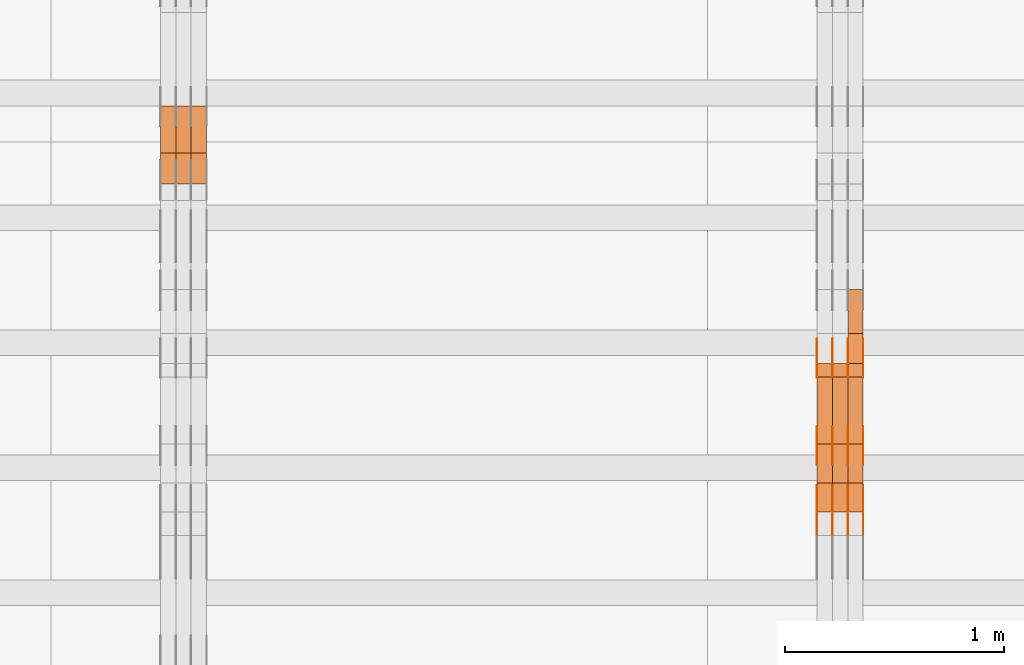
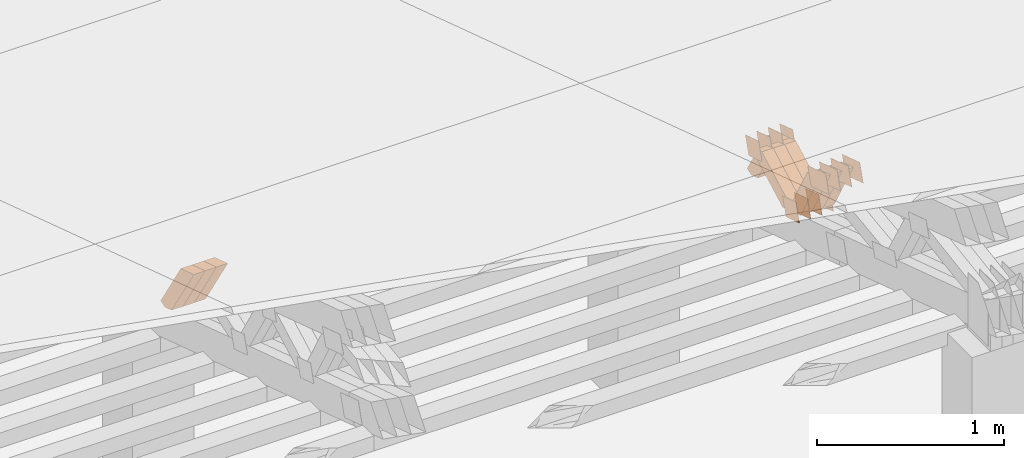
# One storey, part 225 of 385: 28 proxies.
"""IFC2X3 building model written with IfcOpenShell, lengths in millimetres."""

from ifc_helpers import new_model, entity, si_unit, converted_unit, derived_unit, direction, frame, origin, place, context, subcontext, project, spatial, polyline, outline, extrude, source, transform, mapped, material, type_object, type_shapes, element, save


model = new_model("IFC2X3")

# Units and contexts
model_context = context("Model", 3, precision=0.01, world=origin(), true_north=direction((6.12303176911189e-17, 1.0)))
body_context = subcontext(model_context, "Body", "Model", "MODEL_VIEW")
ifc_project = project(units=[si_unit("LENGTHUNIT", "METRE", prefix="MILLI"), si_unit("AREAUNIT", "SQUARE_METRE"), si_unit("VOLUMEUNIT", "CUBIC_METRE"), converted_unit("PLANEANGLEUNIT", "DEGREE", entity("IfcRatioMeasure", 0.0174532925199433), si_unit("PLANEANGLEUNIT", "RADIAN"), dimensions=[0, 0, 0, 0, 0, 0, 0]), si_unit("MASSUNIT", "GRAM", prefix="KILO"), derived_unit("MASSDENSITYUNIT", [(si_unit("MASSUNIT", "GRAM", prefix="KILO"), 1), (si_unit("LENGTHUNIT", "METRE"), -3)]), si_unit("TIMEUNIT", "SECOND"), si_unit("FREQUENCYUNIT", "HERTZ"), si_unit("THERMODYNAMICTEMPERATUREUNIT", "DEGREE_CELSIUS"), derived_unit("THERMALTRANSMITTANCEUNIT", [(si_unit("MASSUNIT", "GRAM", prefix="KILO"), 1), (si_unit("THERMODYNAMICTEMPERATUREUNIT", "KELVIN"), -1), (si_unit("TIMEUNIT", "SECOND"), -3)]), derived_unit("VOLUMETRICFLOWRATEUNIT", [(si_unit("LENGTHUNIT", "METRE"), 3), (si_unit("TIMEUNIT", "SECOND"), -1)]), si_unit("ELECTRICCURRENTUNIT", "AMPERE"), si_unit("ELECTRICVOLTAGEUNIT", "VOLT"), si_unit("POWERUNIT", "WATT"), si_unit("FORCEUNIT", "NEWTON", prefix="KILO"), si_unit("ILLUMINANCEUNIT", "LUX"), si_unit("LUMINOUSFLUXUNIT", "LUMEN"), si_unit("LUMINOUSINTENSITYUNIT", "CANDELA"), derived_unit("USERDEFINED", [(si_unit("MASSUNIT", "GRAM", prefix="KILO"), -1), (si_unit("LENGTHUNIT", "METRE"), -2), (si_unit("TIMEUNIT", "SECOND"), 3), (si_unit("LUMINOUSFLUXUNIT", "LUMEN"), 1)]), derived_unit("LINEARVELOCITYUNIT", [(si_unit("LENGTHUNIT", "METRE"), 1), (si_unit("TIMEUNIT", "SECOND"), -1)]), si_unit("PRESSUREUNIT", "PASCAL"), derived_unit("USERDEFINED", [(si_unit("LENGTHUNIT", "METRE"), -2), (si_unit("MASSUNIT", "GRAM", prefix="KILO"), 1), (si_unit("TIMEUNIT", "SECOND"), -2)])], contexts=[model_context])

# Site, building, storey
site_placement = place(None, origin())
site = spatial("IfcSite", under=ifc_project, at=site_placement, CompositionType="ELEMENT")
building_placement = place(site_placement, origin())
building = spatial("IfcBuilding", under=site, at=building_placement, CompositionType="ELEMENT")
storey_placement = place(building_placement, origin())
storey = spatial("IfcBuildingStorey", under=building, at=storey_placement, Name="Default", CompositionType="ELEMENT", Elevation=0.0)

# Proxies
ifc_material_1 = material(Name="IfcSurfaceStyle #348578")
building_element_proxy_type_1 = type_object("IfcBuildingElementProxyType", PredefinedType="NOTDEFINED", material=ifc_material_1)
shared_shape_1 = source(origin(), body_context, "Body", "SweptSolid", [
    extrude(outline(polyline([(-74.9998982809088, -60.000042563519), (74.9998377068237, -60.000042563519), (74.9998982809079, 60.0000425635189), (-74.9998377068227, 60.0000425635189), (-74.9998982809088, -60.000042563519)])), frame((75.0001050385304, 60.0001177331169, 0.0), z_axis=(0.0, 0.0, 1.0), x_axis=(-1.0, 0.0, 0.0)), (0.0, 0.0, 1.0), 1.3),
])
type_shapes(building_element_proxy_type_1, [shared_shape_1])
proxy_1_placement = place(building_placement, frame((27386.3, 19806.7306653882, 2506.65203571776), z_axis=(-1.0, 0.0, 0.0), x_axis=(0.0, -0.951056516295154, 0.309016994374948)))
element("IfcBuildingElementProxy", 1, at=proxy_1_placement, inside=storey, type_object=building_element_proxy_type_1, material=ifc_material_1, context=body_context, shape_type="MappedRepresentation", body=[
    mapped(shared_shape_1, transform((0.0, 0.0, 0.0), scale=1.0)),
])
ifc_material_2 = material(Name="IfcSurfaceStyle #348521")
building_element_proxy_type_2 = type_object("IfcBuildingElementProxyType", PredefinedType="NOTDEFINED", material=ifc_material_2)
shared_shape_2 = source(origin(), body_context, "Body", "SweptSolid", [
    extrude(outline(polyline([(-74.9998982809088, -60.000042563519), (74.9998377068237, -60.000042563519), (74.9998982809079, 60.0000425635189), (-74.9998377068227, 60.0000425635189), (-74.9998982809088, -60.000042563519)])), frame((75.0001050385304, 60.0001177331169, 0.0), z_axis=(0.0, 0.0, 1.0), x_axis=(-1.0, 0.0, 0.0)), (0.0, 0.0, 1.0), 1.3),
])
type_shapes(building_element_proxy_type_2, [shared_shape_2])
proxy_2_placement = place(building_placement, frame((27315.0, 19806.7306653882, 2506.65203571776), z_axis=(-1.0, 0.0, 0.0), x_axis=(0.0, -0.951056516295154, 0.309016994374948)))
element("IfcBuildingElementProxy", 2, at=proxy_2_placement, inside=storey, type_object=building_element_proxy_type_2, material=ifc_material_2, context=body_context, shape_type="MappedRepresentation", body=[
    mapped(shared_shape_2, transform((0.0, 0.0, 0.0), scale=1.0)),
])
ifc_material_3 = material(Name="IfcSurfaceStyle #348464")
building_element_proxy_type_3 = type_object("IfcBuildingElementProxyType", PredefinedType="NOTDEFINED", material=ifc_material_3)
shared_shape_3 = source(origin(), body_context, "Body", "SweptSolid", [
    extrude(outline(polyline([(-74.9998982809088, -60.000042563519), (74.9998377068237, -60.000042563519), (74.9998982809079, 60.0000425635189), (-74.9998377068227, 60.0000425635189), (-74.9998982809088, -60.000042563519)])), frame((75.0001050385304, 60.0001177331169, 0.0), z_axis=(0.0, 0.0, 1.0), x_axis=(-1.0, 0.0, 0.0)), (0.0, 0.0, 1.0), 1.3),
])
type_shapes(building_element_proxy_type_3, [shared_shape_3])
proxy_3_placement = place(building_placement, frame((27316.3, 19806.7306653882, 2506.65203571776), z_axis=(-1.0, 0.0, 0.0), x_axis=(0.0, -0.951056516295154, 0.309016994374948)))
element("IfcBuildingElementProxy", 3, at=proxy_3_placement, inside=storey, type_object=building_element_proxy_type_3, material=ifc_material_3, context=body_context, shape_type="MappedRepresentation", body=[
    mapped(shared_shape_3, transform((0.0, 0.0, 0.0), scale=1.0)),
])
ifc_material_4 = material(Name="IfcSurfaceStyle #348407")
building_element_proxy_type_4 = type_object("IfcBuildingElementProxyType", PredefinedType="NOTDEFINED", material=ifc_material_4)
shared_shape_4 = source(origin(), body_context, "Body", "SweptSolid", [
    extrude(outline(polyline([(-74.9998982809088, -60.000042563519), (74.9998377068237, -60.000042563519), (74.9998982809079, 60.0000425635189), (-74.9998377068227, 60.0000425635189), (-74.9998982809088, -60.000042563519)])), frame((75.0001050385304, 60.0001177331169, 0.0), z_axis=(0.0, 0.0, 1.0), x_axis=(-1.0, 0.0, 0.0)), (0.0, 0.0, 1.0), 1.29999999999999),
])
type_shapes(building_element_proxy_type_4, [shared_shape_4])
proxy_4_placement = place(building_placement, frame((27245.0, 19806.7306653882, 2506.65203571776), z_axis=(-1.0, 0.0, 0.0), x_axis=(0.0, -0.951056516295154, 0.309016994374948)))
element("IfcBuildingElementProxy", 4, at=proxy_4_placement, inside=storey, type_object=building_element_proxy_type_4, material=ifc_material_4, context=body_context, shape_type="MappedRepresentation", body=[
    mapped(shared_shape_4, transform((0.0, 0.0, 0.0), scale=1.0)),
])
ifc_material_5 = material(Name="IfcSurfaceStyle #348350")
building_element_proxy_type_5 = type_object("IfcBuildingElementProxyType", PredefinedType="NOTDEFINED", material=ifc_material_5)
shared_shape_5 = source(origin(), body_context, "Body", "SweptSolid", [
    extrude(outline(polyline([(-74.9998982809088, -60.000042563519), (74.9998377068237, -60.000042563519), (74.9998982809079, 60.0000425635189), (-74.9998377068227, 60.0000425635189), (-74.9998982809088, -60.000042563519)])), frame((75.0001050385304, 60.0001177331169, 0.0), z_axis=(0.0, 0.0, 1.0), x_axis=(-1.0, 0.0, 0.0)), (0.0, 0.0, 1.0), 1.29999999999999),
])
type_shapes(building_element_proxy_type_5, [shared_shape_5])
proxy_5_placement = place(building_placement, frame((27246.3, 19806.7306653882, 2506.65203571776), z_axis=(-1.0, 0.0, 0.0), x_axis=(0.0, -0.951056516295154, 0.309016994374948)))
element("IfcBuildingElementProxy", 5, at=proxy_5_placement, inside=storey, type_object=building_element_proxy_type_5, material=ifc_material_5, context=body_context, shape_type="MappedRepresentation", body=[
    mapped(shared_shape_5, transform((0.0, 0.0, 0.0), scale=1.0)),
])
ifc_material_6 = material(Name="IfcSurfaceStyle #348293")
building_element_proxy_type_6 = type_object("IfcBuildingElementProxyType", PredefinedType="NOTDEFINED", material=ifc_material_6)
shared_shape_6 = source(origin(), body_context, "Body", "SweptSolid", [
    extrude(outline(polyline([(-74.9998982809088, -60.000042563519), (74.9998377068237, -60.000042563519), (74.9998982809079, 60.0000425635189), (-74.9998377068227, 60.0000425635189), (-74.9998982809088, -60.000042563519)])), frame((75.0001050385304, 60.0001177331169, 0.0), z_axis=(0.0, 0.0, 1.0), x_axis=(-1.0, 0.0, 0.0)), (0.0, 0.0, 1.0), 1.29999999999999),
])
type_shapes(building_element_proxy_type_6, [shared_shape_6])
proxy_6_placement = place(building_placement, frame((27175.0, 19806.7306653882, 2506.65203571776), z_axis=(-1.0, 0.0, 0.0), x_axis=(0.0, -0.951056516295154, 0.309016994374948)))
element("IfcBuildingElementProxy", 6, at=proxy_6_placement, inside=storey, type_object=building_element_proxy_type_6, material=ifc_material_6, context=body_context, shape_type="MappedRepresentation", body=[
    mapped(shared_shape_6, transform((0.0, 0.0, 0.0), scale=1.0)),
])
ifc_material_7 = material(Name="IfcSurfaceStyle #347210")
building_element_proxy_type_7 = type_object("IfcBuildingElementProxyType", PredefinedType="NOTDEFINED", material=ifc_material_7)
shared_shape_7 = source(origin(), body_context, "Body", "SweptSolid", [
    extrude(outline(polyline([(-99.9998479918963, -59.9999913366637), (99.9998251396114, -59.9999913366637), (99.9998102700952, 59.9999913366637), (-99.9997874178102, 59.9999913366637), (-99.9998479918963, -59.9999913366637)])), frame((99.9998251396114, 60.0000609537942, 0.0), z_axis=(0.0, 0.0, 1.0), x_axis=(-1.0, 0.0, 0.0)), (0.0, 0.0, 1.0), 1.3),
])
type_shapes(building_element_proxy_type_7, [shared_shape_7])
proxy_7_placement = place(building_placement, frame((27386.3, 19136.9072023289, 2711.67346128215), z_axis=(-1.0, 0.0, 0.0), x_axis=(0.0, -0.951056516295154, 0.309016994374948)))
element("IfcBuildingElementProxy", 7, at=proxy_7_placement, inside=storey, type_object=building_element_proxy_type_7, material=ifc_material_7, context=body_context, shape_type="MappedRepresentation", body=[
    mapped(shared_shape_7, transform((0.0, 0.0, 0.0), scale=1.0)),
])
ifc_material_8 = material(Name="IfcSurfaceStyle #347153")
building_element_proxy_type_8 = type_object("IfcBuildingElementProxyType", PredefinedType="NOTDEFINED", material=ifc_material_8)
shared_shape_8 = source(origin(), body_context, "Body", "SweptSolid", [
    extrude(outline(polyline([(-99.9998479918963, -59.9999913366637), (99.9998251396114, -59.9999913366637), (99.9998102700952, 59.9999913366637), (-99.9997874178102, 59.9999913366637), (-99.9998479918963, -59.9999913366637)])), frame((99.9998251396114, 60.0000609537942, 0.0), z_axis=(0.0, 0.0, 1.0), x_axis=(-1.0, 0.0, 0.0)), (0.0, 0.0, 1.0), 1.3),
])
type_shapes(building_element_proxy_type_8, [shared_shape_8])
proxy_8_placement = place(building_placement, frame((27315.0, 19136.9072023289, 2711.67346128215), z_axis=(-1.0, 0.0, 0.0), x_axis=(0.0, -0.951056516295154, 0.309016994374948)))
element("IfcBuildingElementProxy", 8, at=proxy_8_placement, inside=storey, type_object=building_element_proxy_type_8, material=ifc_material_8, context=body_context, shape_type="MappedRepresentation", body=[
    mapped(shared_shape_8, transform((0.0, 0.0, 0.0), scale=1.0)),
])
ifc_material_9 = material(Name="IfcSurfaceStyle #347096")
building_element_proxy_type_9 = type_object("IfcBuildingElementProxyType", PredefinedType="NOTDEFINED", material=ifc_material_9)
shared_shape_9 = source(origin(), body_context, "Body", "SweptSolid", [
    extrude(outline(polyline([(-99.9998479918963, -59.9999913366637), (99.9998251396114, -59.9999913366637), (99.9998102700952, 59.9999913366637), (-99.9997874178102, 59.9999913366637), (-99.9998479918963, -59.9999913366637)])), frame((99.9998251396114, 60.0000609537942, 0.0), z_axis=(0.0, 0.0, 1.0), x_axis=(-1.0, 0.0, 0.0)), (0.0, 0.0, 1.0), 1.3),
])
type_shapes(building_element_proxy_type_9, [shared_shape_9])
proxy_9_placement = place(building_placement, frame((27316.3, 19136.9072023289, 2711.67346128215), z_axis=(-1.0, 0.0, 0.0), x_axis=(0.0, -0.951056516295154, 0.309016994374948)))
element("IfcBuildingElementProxy", 9, at=proxy_9_placement, inside=storey, type_object=building_element_proxy_type_9, material=ifc_material_9, context=body_context, shape_type="MappedRepresentation", body=[
    mapped(shared_shape_9, transform((0.0, 0.0, 0.0), scale=1.0)),
])
ifc_material_10 = material(Name="IfcSurfaceStyle #347039")
building_element_proxy_type_10 = type_object("IfcBuildingElementProxyType", PredefinedType="NOTDEFINED", material=ifc_material_10)
shared_shape_10 = source(origin(), body_context, "Body", "SweptSolid", [
    extrude(outline(polyline([(-99.9998479918963, -59.9999913366637), (99.9998251396114, -59.9999913366637), (99.9998102700952, 59.9999913366637), (-99.9997874178102, 59.9999913366637), (-99.9998479918963, -59.9999913366637)])), frame((99.9998251396114, 60.0000609537942, 0.0), z_axis=(0.0, 0.0, 1.0), x_axis=(-1.0, 0.0, 0.0)), (0.0, 0.0, 1.0), 1.29999999999998),
])
type_shapes(building_element_proxy_type_10, [shared_shape_10])
proxy_10_placement = place(building_placement, frame((27245.0, 19136.9072023289, 2711.67346128215), z_axis=(-1.0, 0.0, 0.0), x_axis=(0.0, -0.951056516295154, 0.309016994374948)))
element("IfcBuildingElementProxy", 10, at=proxy_10_placement, inside=storey, type_object=building_element_proxy_type_10, material=ifc_material_10, context=body_context, shape_type="MappedRepresentation", body=[
    mapped(shared_shape_10, transform((0.0, 0.0, 0.0), scale=1.0)),
])
ifc_material_11 = material(Name="IfcSurfaceStyle #346982")
building_element_proxy_type_11 = type_object("IfcBuildingElementProxyType", PredefinedType="NOTDEFINED", material=ifc_material_11)
shared_shape_11 = source(origin(), body_context, "Body", "SweptSolid", [
    extrude(outline(polyline([(-99.9998479918963, -59.9999913366637), (99.9998251396114, -59.9999913366637), (99.9998102700952, 59.9999913366637), (-99.9997874178102, 59.9999913366637), (-99.9998479918963, -59.9999913366637)])), frame((99.9998251396114, 60.0000609537942, 0.0), z_axis=(0.0, 0.0, 1.0), x_axis=(-1.0, 0.0, 0.0)), (0.0, 0.0, 1.0), 1.29999999999998),
])
type_shapes(building_element_proxy_type_11, [shared_shape_11])
proxy_11_placement = place(building_placement, frame((27246.3, 19136.9072023289, 2711.67346128215), z_axis=(-1.0, 0.0, 0.0), x_axis=(0.0, -0.951056516295154, 0.309016994374948)))
element("IfcBuildingElementProxy", 11, at=proxy_11_placement, inside=storey, type_object=building_element_proxy_type_11, material=ifc_material_11, context=body_context, shape_type="MappedRepresentation", body=[
    mapped(shared_shape_11, transform((0.0, 0.0, 0.0), scale=1.0)),
])
ifc_material_12 = material(Name="IfcSurfaceStyle #346925")
building_element_proxy_type_12 = type_object("IfcBuildingElementProxyType", PredefinedType="NOTDEFINED", material=ifc_material_12)
shared_shape_12 = source(origin(), body_context, "Body", "SweptSolid", [
    extrude(outline(polyline([(-99.9998479918963, -59.9999913366637), (99.9998251396114, -59.9999913366637), (99.9998102700952, 59.9999913366637), (-99.9997874178102, 59.9999913366637), (-99.9998479918963, -59.9999913366637)])), frame((99.9998251396114, 60.0000609537942, 0.0), z_axis=(0.0, 0.0, 1.0), x_axis=(-1.0, 0.0, 0.0)), (0.0, 0.0, 1.0), 1.29999999999999),
])
type_shapes(building_element_proxy_type_12, [shared_shape_12])
proxy_12_placement = place(building_placement, frame((27175.0, 19136.9072023289, 2711.67346128215), z_axis=(-1.0, 0.0, 0.0), x_axis=(0.0, -0.951056516295154, 0.309016994374948)))
element("IfcBuildingElementProxy", 12, at=proxy_12_placement, inside=storey, type_object=building_element_proxy_type_12, material=ifc_material_12, context=body_context, shape_type="MappedRepresentation", body=[
    mapped(shared_shape_12, transform((0.0, 0.0, 0.0), scale=1.0)),
])
ifc_material_13 = material(Name="IfcSurfaceStyle #342080")
building_element_proxy_type_13 = type_object("IfcBuildingElementProxyType", PredefinedType="NOTDEFINED", material=ifc_material_13)
shared_shape_13 = source(origin(), body_context, "Body", "SweptSolid", [
    extrude(outline(polyline([(-74.9998605591127, -59.9999264677599), (74.999875428618, -59.9999264677599), (74.9998605591127, 59.9999264677599), (-74.999875428618, 59.9999264677599), (-74.9998605591127, -59.9999264677599)])), frame((75.0002655673825, 60.0000016373433, 0.0), z_axis=(0.0, 0.0, 1.0), x_axis=(-1.0, 0.0, 0.0)), (0.0, 0.0, 1.0), 1.3),
])
type_shapes(building_element_proxy_type_13, [shared_shape_13])
proxy_13_placement = place(building_placement, frame((27386.3, 19407.1136664358, 2348.71056820494), z_axis=(-1.0, 0.0, 0.0), x_axis=(0.0, -0.951056516295124, 0.309016994375039)))
element("IfcBuildingElementProxy", 13, at=proxy_13_placement, inside=storey, type_object=building_element_proxy_type_13, material=ifc_material_13, context=body_context, shape_type="MappedRepresentation", body=[
    mapped(shared_shape_13, transform((0.0, 0.0, 0.0), scale=1.0)),
])
ifc_material_14 = material(Name="IfcSurfaceStyle #342023")
building_element_proxy_type_14 = type_object("IfcBuildingElementProxyType", PredefinedType="NOTDEFINED", material=ifc_material_14)
shared_shape_14 = source(origin(), body_context, "Body", "SweptSolid", [
    extrude(outline(polyline([(-74.9998605591127, -59.9999264677599), (74.999875428618, -59.9999264677599), (74.9998605591127, 59.9999264677599), (-74.999875428618, 59.9999264677599), (-74.9998605591127, -59.9999264677599)])), frame((75.0002655673825, 60.0000016373433, 0.0), z_axis=(0.0, 0.0, 1.0), x_axis=(-1.0, 0.0, 0.0)), (0.0, 0.0, 1.0), 1.3),
])
type_shapes(building_element_proxy_type_14, [shared_shape_14])
proxy_14_placement = place(building_placement, frame((27315.0, 19407.1136664358, 2348.71056820494), z_axis=(-1.0, 0.0, 0.0), x_axis=(0.0, -0.951056516295124, 0.309016994375039)))
element("IfcBuildingElementProxy", 14, at=proxy_14_placement, inside=storey, type_object=building_element_proxy_type_14, material=ifc_material_14, context=body_context, shape_type="MappedRepresentation", body=[
    mapped(shared_shape_14, transform((0.0, 0.0, 0.0), scale=1.0)),
])
ifc_material_15 = material(Name="IfcSurfaceStyle #341966")
building_element_proxy_type_15 = type_object("IfcBuildingElementProxyType", PredefinedType="NOTDEFINED", material=ifc_material_15)
shared_shape_15 = source(origin(), body_context, "Body", "SweptSolid", [
    extrude(outline(polyline([(-74.9998605591127, -59.9999264677599), (74.999875428618, -59.9999264677599), (74.9998605591127, 59.9999264677599), (-74.999875428618, 59.9999264677599), (-74.9998605591127, -59.9999264677599)])), frame((75.0002655673825, 60.0000016373433, 0.0), z_axis=(0.0, 0.0, 1.0), x_axis=(-1.0, 0.0, 0.0)), (0.0, 0.0, 1.0), 1.3),
])
type_shapes(building_element_proxy_type_15, [shared_shape_15])
proxy_15_placement = place(building_placement, frame((27316.3, 19407.1136664358, 2348.71056820494), z_axis=(-1.0, 0.0, 0.0), x_axis=(0.0, -0.951056516295124, 0.309016994375039)))
element("IfcBuildingElementProxy", 15, at=proxy_15_placement, inside=storey, type_object=building_element_proxy_type_15, material=ifc_material_15, context=body_context, shape_type="MappedRepresentation", body=[
    mapped(shared_shape_15, transform((0.0, 0.0, 0.0), scale=1.0)),
])
ifc_material_16 = material(Name="IfcSurfaceStyle #341909")
building_element_proxy_type_16 = type_object("IfcBuildingElementProxyType", PredefinedType="NOTDEFINED", material=ifc_material_16)
shared_shape_16 = source(origin(), body_context, "Body", "SweptSolid", [
    extrude(outline(polyline([(-74.9998605591127, -59.9999264677599), (74.999875428618, -59.9999264677599), (74.9998605591127, 59.9999264677599), (-74.999875428618, 59.9999264677599), (-74.9998605591127, -59.9999264677599)])), frame((75.0002655673825, 60.0000016373433, 0.0), z_axis=(0.0, 0.0, 1.0), x_axis=(-1.0, 0.0, 0.0)), (0.0, 0.0, 1.0), 1.29999999999999),
])
type_shapes(building_element_proxy_type_16, [shared_shape_16])
proxy_16_placement = place(building_placement, frame((27245.0, 19407.1136664358, 2348.71056820494), z_axis=(-1.0, 0.0, 0.0), x_axis=(0.0, -0.951056516295124, 0.309016994375039)))
element("IfcBuildingElementProxy", 16, at=proxy_16_placement, inside=storey, type_object=building_element_proxy_type_16, material=ifc_material_16, context=body_context, shape_type="MappedRepresentation", body=[
    mapped(shared_shape_16, transform((0.0, 0.0, 0.0), scale=1.0)),
])
ifc_material_17 = material(Name="IfcSurfaceStyle #341852")
building_element_proxy_type_17 = type_object("IfcBuildingElementProxyType", PredefinedType="NOTDEFINED", material=ifc_material_17)
shared_shape_17 = source(origin(), body_context, "Body", "SweptSolid", [
    extrude(outline(polyline([(-74.9998605591127, -59.9999264677599), (74.999875428618, -59.9999264677599), (74.9998605591127, 59.9999264677599), (-74.999875428618, 59.9999264677599), (-74.9998605591127, -59.9999264677599)])), frame((75.0002655673825, 60.0000016373433, 0.0), z_axis=(0.0, 0.0, 1.0), x_axis=(-1.0, 0.0, 0.0)), (0.0, 0.0, 1.0), 1.29999999999999),
])
type_shapes(building_element_proxy_type_17, [shared_shape_17])
proxy_17_placement = place(building_placement, frame((27246.3, 19407.1136664358, 2348.71056820494), z_axis=(-1.0, 0.0, 0.0), x_axis=(0.0, -0.951056516295124, 0.309016994375039)))
element("IfcBuildingElementProxy", 17, at=proxy_17_placement, inside=storey, type_object=building_element_proxy_type_17, material=ifc_material_17, context=body_context, shape_type="MappedRepresentation", body=[
    mapped(shared_shape_17, transform((0.0, 0.0, 0.0), scale=1.0)),
])
ifc_material_18 = material(Name="IfcSurfaceStyle #341795")
building_element_proxy_type_18 = type_object("IfcBuildingElementProxyType", PredefinedType="NOTDEFINED", material=ifc_material_18)
shared_shape_18 = source(origin(), body_context, "Body", "SweptSolid", [
    extrude(outline(polyline([(-74.9998605591127, -59.9999264677599), (74.999875428618, -59.9999264677599), (74.9998605591127, 59.9999264677599), (-74.999875428618, 59.9999264677599), (-74.9998605591127, -59.9999264677599)])), frame((75.0002655673825, 60.0000016373433, 0.0), z_axis=(0.0, 0.0, 1.0), x_axis=(-1.0, 0.0, 0.0)), (0.0, 0.0, 1.0), 1.29999999999999),
])
type_shapes(building_element_proxy_type_18, [shared_shape_18])
proxy_18_placement = place(building_placement, frame((27175.0, 19407.1136664358, 2348.71056820494), z_axis=(-1.0, 0.0, 0.0), x_axis=(0.0, -0.951056516295124, 0.309016994375039)))
element("IfcBuildingElementProxy", 18, at=proxy_18_placement, inside=storey, type_object=building_element_proxy_type_18, material=ifc_material_18, context=body_context, shape_type="MappedRepresentation", body=[
    mapped(shared_shape_18, transform((0.0, 0.0, 0.0), scale=1.0)),
])
ifc_material_19 = material(Name="IfcSurfaceStyle #325322")
building_element_proxy_type_19 = type_object("IfcBuildingElementProxyType", Name="T1-W40 325320", PredefinedType="NOTDEFINED", material=ifc_material_19)
shared_shape_19 = source(origin(), body_context, "Body", "SweptSolid", [
    extrude(outline(polyline([(-190.697067347251, -47.4992767218045), (178.704677543904, -47.4992767218045), (178.119540532346, -0.000296092407564622), (126.935785980356, 47.4999913795318), (-293.062936709355, 47.4988581564849), (-190.697067347251, -47.4992767218045)])), frame((178.7049897723, 47.4999913795318, 0.0), z_axis=(0.0, 0.0, 1.0), x_axis=(-1.0, 0.0, 0.0)), (0.0, 0.0, 1.0), 70.0),
])
type_shapes(building_element_proxy_type_19, [shared_shape_19])
proxy_19_placement = place(building_placement, frame((27385.0, 19280.269490882, 2403.36730959494), z_axis=(-1.0, 0.0, 0.0), x_axis=(0.0, -0.48691092455798, 0.873451630913866)))
element("IfcBuildingElementProxy", 19, at=proxy_19_placement, inside=storey, type_object=building_element_proxy_type_19, material=ifc_material_19, Name="T1-W40", context=body_context, shape_type="MappedRepresentation", body=[
    mapped(shared_shape_19, transform((0.0, 0.0, 0.0), scale=1.0)),
])
ifc_material_20 = material(Name="IfcSurfaceStyle #325256")
building_element_proxy_type_20 = type_object("IfcBuildingElementProxyType", Name="T1-W40 325254", PredefinedType="NOTDEFINED", material=ifc_material_20)
shared_shape_20 = source(origin(), body_context, "Body", "SweptSolid", [
    extrude(outline(polyline([(-190.697067347251, -47.4992767218045), (178.704677543904, -47.4992767218045), (178.119540532346, -0.000296092407564622), (126.935785980356, 47.4999913795318), (-293.062936709355, 47.4988581564849), (-190.697067347251, -47.4992767218045)])), frame((178.7049897723, 47.4999913795318, 0.0), z_axis=(0.0, 0.0, 1.0), x_axis=(-1.0, 0.0, 0.0)), (0.0, 0.0, 1.0), 70.0),
])
type_shapes(building_element_proxy_type_20, [shared_shape_20])
proxy_20_placement = place(building_placement, frame((27315.0, 19280.269490882, 2403.36730959494), z_axis=(-1.0, 0.0, 0.0), x_axis=(0.0, -0.48691092455798, 0.873451630913866)))
element("IfcBuildingElementProxy", 20, at=proxy_20_placement, inside=storey, type_object=building_element_proxy_type_20, material=ifc_material_20, Name="T1-W40", context=body_context, shape_type="MappedRepresentation", body=[
    mapped(shared_shape_20, transform((0.0, 0.0, 0.0), scale=1.0)),
])
ifc_material_21 = material(Name="IfcSurfaceStyle #325190")
building_element_proxy_type_21 = type_object("IfcBuildingElementProxyType", Name="T1-W40 325188", PredefinedType="NOTDEFINED", material=ifc_material_21)
shared_shape_21 = source(origin(), body_context, "Body", "SweptSolid", [
    extrude(outline(polyline([(-190.697067347251, -47.4992767218045), (178.704677543904, -47.4992767218045), (178.119540532346, -0.000296092407564622), (126.935785980356, 47.4999913795318), (-293.062936709355, 47.4988581564849), (-190.697067347251, -47.4992767218045)])), frame((178.7049897723, 47.4999913795318, 0.0), z_axis=(0.0, 0.0, 1.0), x_axis=(-1.0, 0.0, 0.0)), (0.0, 0.0, 1.0), 70.0),
])
type_shapes(building_element_proxy_type_21, [shared_shape_21])
proxy_21_placement = place(building_placement, frame((27245.0, 19280.269490882, 2403.36730959494), z_axis=(-1.0, 0.0, 0.0), x_axis=(0.0, -0.48691092455798, 0.873451630913866)))
element("IfcBuildingElementProxy", 21, at=proxy_21_placement, inside=storey, type_object=building_element_proxy_type_21, material=ifc_material_21, Name="T1-W40", context=body_context, shape_type="MappedRepresentation", body=[
    mapped(shared_shape_21, transform((0.0, 0.0, 0.0), scale=1.0)),
])
ifc_material_22 = material(Name="IfcSurfaceStyle #324926")
building_element_proxy_type_22 = type_object("IfcBuildingElementProxyType", Name="T1-W47 324924", PredefinedType="NOTDEFINED", material=ifc_material_22)
shared_shape_22 = source(origin(), body_context, "Body", "SweptSolid", [
    extrude(outline(polyline([(-273.154581805017, -47.5000119135351), (121.157675769026, -47.5000119135351), (166.341960897813, -0.000128144957132403), (168.441931699108, 47.5000759860137), (-182.78698656093, 47.5000759860137), (-273.154581805017, -47.5000119135351)])), frame((168.441931699108, 47.5000759860137, 0.0), z_axis=(0.0, 0.0, 1.0), x_axis=(-1.0, 0.0, 0.0)), (0.0, 0.0, 1.0), 70.0),
])
type_shapes(building_element_proxy_type_22, [shared_shape_22])
proxy_22_placement = place(building_placement, frame((27385.0, 19755.0380859375, 2553.712890625), z_axis=(-1.0, 0.0, 0.0), x_axis=(0.0, -0.879386813332609, -0.476108005117242)))
element("IfcBuildingElementProxy", 22, at=proxy_22_placement, inside=storey, type_object=building_element_proxy_type_22, material=ifc_material_22, Name="T1-W47", context=body_context, shape_type="MappedRepresentation", body=[
    mapped(shared_shape_22, transform((0.0, 0.0, 0.0), scale=1.0)),
])
ifc_material_23 = material(Name="IfcSurfaceStyle #324860")
building_element_proxy_type_23 = type_object("IfcBuildingElementProxyType", Name="T1-W47 324858", PredefinedType="NOTDEFINED", material=ifc_material_23)
shared_shape_23 = source(origin(), body_context, "Body", "SweptSolid", [
    extrude(outline(polyline([(-273.154581805017, -47.5000119135351), (121.157675769026, -47.5000119135351), (166.341960897813, -0.000128144957132403), (168.441931699108, 47.5000759860137), (-182.78698656093, 47.5000759860137), (-273.154581805017, -47.5000119135351)])), frame((168.441931699108, 47.5000759860137, 0.0), z_axis=(0.0, 0.0, 1.0), x_axis=(-1.0, 0.0, 0.0)), (0.0, 0.0, 1.0), 70.0),
])
type_shapes(building_element_proxy_type_23, [shared_shape_23])
proxy_23_placement = place(building_placement, frame((27315.0, 19755.0380859375, 2553.712890625), z_axis=(-1.0, 0.0, 0.0), x_axis=(0.0, -0.879386813332609, -0.476108005117242)))
element("IfcBuildingElementProxy", 23, at=proxy_23_placement, inside=storey, type_object=building_element_proxy_type_23, material=ifc_material_23, Name="T1-W47", context=body_context, shape_type="MappedRepresentation", body=[
    mapped(shared_shape_23, transform((0.0, 0.0, 0.0), scale=1.0)),
])
ifc_material_24 = material(Name="IfcSurfaceStyle #324794")
building_element_proxy_type_24 = type_object("IfcBuildingElementProxyType", Name="T1-W47 324792", PredefinedType="NOTDEFINED", material=ifc_material_24)
shared_shape_24 = source(origin(), body_context, "Body", "SweptSolid", [
    extrude(outline(polyline([(-273.154581805017, -47.5000119135351), (121.157675769026, -47.5000119135351), (166.341960897813, -0.000128144957132403), (168.441931699108, 47.5000759860137), (-182.78698656093, 47.5000759860137), (-273.154581805017, -47.5000119135351)])), frame((168.441931699108, 47.5000759860137, 0.0), z_axis=(0.0, 0.0, 1.0), x_axis=(-1.0, 0.0, 0.0)), (0.0, 0.0, 1.0), 70.0),
])
type_shapes(building_element_proxy_type_24, [shared_shape_24])
proxy_24_placement = place(building_placement, frame((27245.0, 19755.0380859375, 2553.712890625), z_axis=(-1.0, 0.0, 0.0), x_axis=(0.0, -0.879386813332609, -0.476108005117242)))
element("IfcBuildingElementProxy", 24, at=proxy_24_placement, inside=storey, type_object=building_element_proxy_type_24, material=ifc_material_24, Name="T1-W47", context=body_context, shape_type="MappedRepresentation", body=[
    mapped(shared_shape_24, transform((0.0, 0.0, 0.0), scale=1.0)),
])
ifc_material_25 = material(Name="IfcSurfaceStyle #324530")
building_element_proxy_type_25 = type_object("IfcBuildingElementProxyType", Name="T1-W34 324528", PredefinedType="NOTDEFINED", material=ifc_material_25)
shared_shape_25 = source(origin(), body_context, "Body", "SweptSolid", [
    extrude(outline(polyline([(-197.657161937088, -47.499796538607), (193.17680883218, -47.499796538607), (182.92464491562, -1.98968224184526e-05), (128.354123102956, 47.4998064870182), (-306.798414913668, 47.4998064870182), (-197.657161937088, -47.499796538607)])), frame((193.176852028916, 47.4998566383869, 0.0), z_axis=(0.0, 0.0, 1.0), x_axis=(-1.0, 0.0, 0.0)), (0.0, 0.0, 1.0), 70.0),
])
type_shapes(building_element_proxy_type_25, [shared_shape_25])
proxy_25_placement = place(building_placement, frame((27385.0, 19987.8030409043, 2165.75390635484), z_axis=(-1.0, 0.0, 0.0), x_axis=(0.0, -0.514479403471631, 0.857502736674044)))
element("IfcBuildingElementProxy", 25, at=proxy_25_placement, inside=storey, type_object=building_element_proxy_type_25, material=ifc_material_25, Name="T1-W34", context=body_context, shape_type="MappedRepresentation", body=[
    mapped(shared_shape_25, transform((0.0, 0.0, 0.0), scale=1.0)),
])
ifc_material_26 = material(Name="IfcSurfaceStyle #289306")
building_element_proxy_type_26 = type_object("IfcBuildingElementProxyType", Name="T1-W29 289304", PredefinedType="NOTDEFINED", material=ifc_material_26)
shared_shape_26 = source(origin(), body_context, "Body", "SweptSolid", [
    extrude(outline(polyline([(-202.325994317059, -47.5000867467013), (200.714255560873, -47.5000867467013), (187.834128885383, 0.000593513395139059), (130.590899902046, 47.4997899900038), (-316.813290031243, 47.4997899900038), (-202.325994317059, -47.5000867467013)])), frame((200.714255560873, 47.5001935424745, 0.0), z_axis=(0.0, 0.0, 1.0), x_axis=(-1.0, 0.0, 0.0)), (0.0, 0.0, 1.0), 70.0),
])
type_shapes(building_element_proxy_type_26, [shared_shape_26])
proxy_26_placement = place(building_placement, frame((24385.0, 20827.0771193222, 1890.72342063252), z_axis=(-1.0, 0.0, 0.0), x_axis=(0.0, -0.534567451138397, 0.845125813227473)))
element("IfcBuildingElementProxy", 26, at=proxy_26_placement, inside=storey, type_object=building_element_proxy_type_26, material=ifc_material_26, Name="T1-W29", context=body_context, shape_type="MappedRepresentation", body=[
    mapped(shared_shape_26, transform((0.0, 0.0, 0.0), scale=1.0)),
])
ifc_material_27 = material(Name="IfcSurfaceStyle #289240")
building_element_proxy_type_27 = type_object("IfcBuildingElementProxyType", Name="T1-W29 289238", PredefinedType="NOTDEFINED", material=ifc_material_27)
shared_shape_27 = source(origin(), body_context, "Body", "SweptSolid", [
    extrude(outline(polyline([(-202.325994317059, -47.5000867467013), (200.714255560873, -47.5000867467013), (187.834128885383, 0.000593513395139059), (130.590899902046, 47.4997899900038), (-316.813290031243, 47.4997899900038), (-202.325994317059, -47.5000867467013)])), frame((200.714255560873, 47.5001935424745, 0.0), z_axis=(0.0, 0.0, 1.0), x_axis=(-1.0, 0.0, 0.0)), (0.0, 0.0, 1.0), 70.0),
])
type_shapes(building_element_proxy_type_27, [shared_shape_27])
proxy_27_placement = place(building_placement, frame((24315.0, 20827.0771193222, 1890.72342063252), z_axis=(-1.0, 0.0, 0.0), x_axis=(0.0, -0.534567451138397, 0.845125813227473)))
element("IfcBuildingElementProxy", 27, at=proxy_27_placement, inside=storey, type_object=building_element_proxy_type_27, material=ifc_material_27, Name="T1-W29", context=body_context, shape_type="MappedRepresentation", body=[
    mapped(shared_shape_27, transform((0.0, 0.0, 0.0), scale=1.0)),
])
ifc_material_28 = material(Name="IfcSurfaceStyle #289174")
building_element_proxy_type_28 = type_object("IfcBuildingElementProxyType", Name="T1-W29 289172", PredefinedType="NOTDEFINED", material=ifc_material_28)
shared_shape_28 = source(origin(), body_context, "Body", "SweptSolid", [
    extrude(outline(polyline([(-202.325994317059, -47.5000867467013), (200.714255560873, -47.5000867467013), (187.834128885383, 0.000593513395139059), (130.590899902046, 47.4997899900038), (-316.813290031243, 47.4997899900038), (-202.325994317059, -47.5000867467013)])), frame((200.714255560873, 47.5001935424745, 0.0), z_axis=(0.0, 0.0, 1.0), x_axis=(-1.0, 0.0, 0.0)), (0.0, 0.0, 1.0), 70.0),
])
type_shapes(building_element_proxy_type_28, [shared_shape_28])
proxy_28_placement = place(building_placement, frame((24245.0, 20827.0771193222, 1890.72342063252), z_axis=(-1.0, 0.0, 0.0), x_axis=(0.0, -0.534567451138397, 0.845125813227473)))
element("IfcBuildingElementProxy", 28, at=proxy_28_placement, inside=storey, type_object=building_element_proxy_type_28, material=ifc_material_28, Name="T1-W29", context=body_context, shape_type="MappedRepresentation", body=[
    mapped(shared_shape_28, transform((0.0, 0.0, 0.0), scale=1.0)),
])

save(model, "model.ifc")
